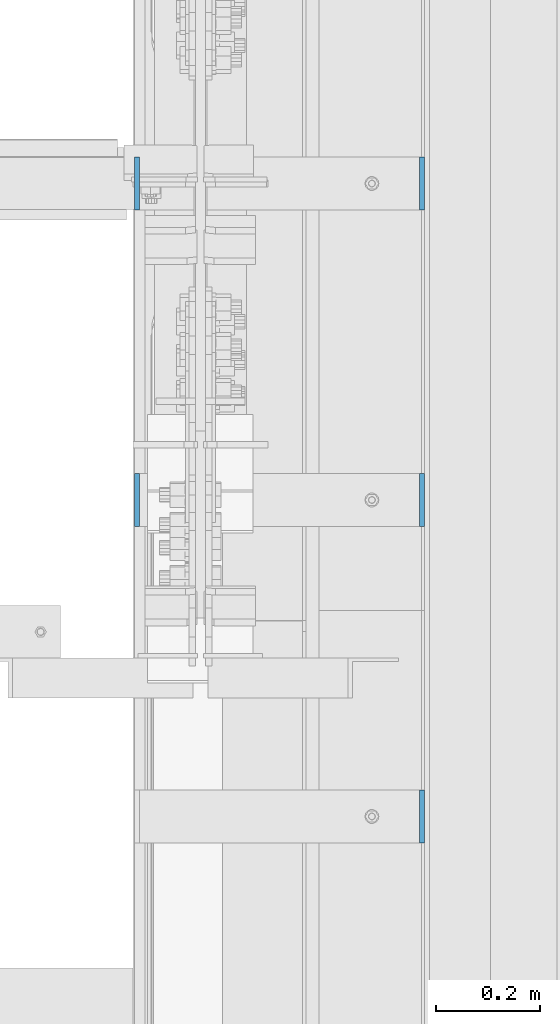
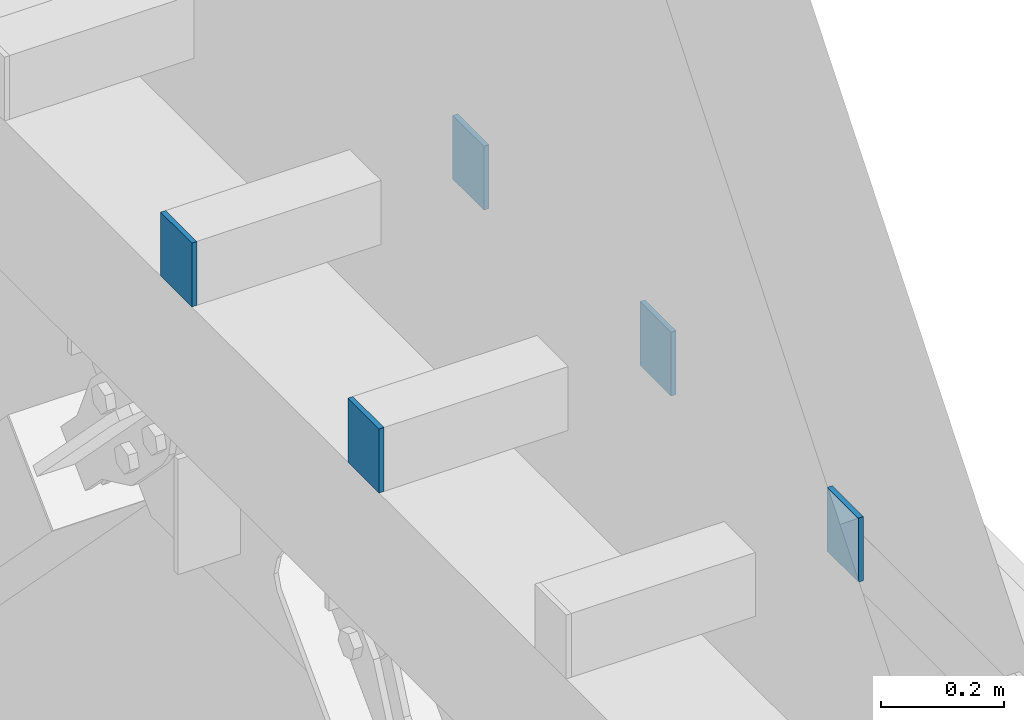
# One storey, part 414 of 1179: 5 columns, 3 elements without a shape of their own.
"""IFC2X3 building model written with IfcOpenShell, lengths in millimetres."""

from ifc_helpers import new_model, si_unit, frame, origin_with_axes, place, context, subcontext, project, spatial, faceted_brep, material, type_object, element, aggregate, save


model = new_model("IFC2X3")

# Units and contexts
model_context = context("Model", 3, precision=1e-05, world=origin_with_axes())
body_context = subcontext(model_context, "Body", "Model", "MODEL_VIEW")
ifc_project = project(units=[si_unit("LENGTHUNIT", "METRE", prefix="MILLI"), si_unit("AREAUNIT", "SQUARE_METRE"), si_unit("VOLUMEUNIT", "CUBIC_METRE"), si_unit("MASSUNIT", "GRAM", prefix="KILO"), si_unit("TIMEUNIT", "SECOND"), si_unit("PLANEANGLEUNIT", "RADIAN"), si_unit("SOLIDANGLEUNIT", "STERADIAN"), si_unit("THERMODYNAMICTEMPERATUREUNIT", "DEGREE_CELSIUS"), si_unit("LUMINOUSINTENSITYUNIT", "LUMEN")], contexts=[model_context])

# Site, building, storey
site_placement = place(None, origin_with_axes())
site = spatial("IfcSite", under=ifc_project, at=site_placement, CompositionType="ELEMENT")
building_placement = place(site_placement, origin_with_axes())
building = spatial("IfcBuilding", under=site, at=building_placement, Name="Undefined", CompositionType="ELEMENT")
storey_placement = place(building_placement, origin_with_axes())
storey = spatial("IfcBuildingStorey", under=building, at=storey_placement, Name="Undefined", CompositionType="ELEMENT", Elevation=0.0)

# Assembly, columns
assembly_1_placement = place(storey_placement, origin_with_axes())
assembly_1 = element("IfcElementAssembly", 1, at=assembly_1_placement, inside=storey, Name="BEAM", AssemblyPlace="NOTDEFINED", PredefinedType="RIGID_FRAME")
ifc_material = material(Name="STEEL/A36")
column_type = type_object("IfcColumnType", PredefinedType="NOTDEFINED")
column_1_placement = place(assembly_1_placement, frame((24734.8375, 15354.3, 8013.69999998781), z_axis=(0.0, 1.0, 0.0), x_axis=(0.0, 0.0, 1.0)))
column_1 = element("IfcColumn", 2, at=column_1_placement, type_object=column_type, material=ifc_material, Name="PLATE", context=body_context, shape_type="Brep", body=[
    faceted_brep([(0.0, 4.76249999999982, -50.7999999999993), (0.0, 4.76249999999982, 50.7999999999993), (127.000000000371, 4.76249999928405, 50.8000000000002), (127.000000000371, 4.76249999928405, -50.8000000000002), (0.0, -4.76249999999982, 50.7999999999993), (127.0, -4.76250000000073, 50.7999999999993), (0.0, -4.76249999999982, -50.7999999999993), (127.0, -4.76250000000073, -50.7999999999993)], [[[0, 1, 2, 3]], [[1, 4, 5, 2]], [[4, 6, 7, 5]], [[6, 0, 3, 7]], [[5, 7, 3, 2]], [[6, 4, 1, 0]]]),
])
column_2_placement = place(assembly_1_placement, frame((24185.5625, 15354.3, 8013.69999998781), z_axis=(0.0, -1.0, 0.0), x_axis=(0.0, 0.0, 1.0)))
column_2 = element("IfcColumn", 3, at=column_2_placement, type_object=column_type, material=ifc_material, Name="PLATE", context=body_context, shape_type="Brep", body=[
    faceted_brep([(0.0, 4.76249999999982, -50.7999999999993), (0.0, 4.76249999999982, 50.7999999999993), (127.000000000371, 4.76249999928405, 50.8000000000002), (127.000000000371, 4.76249999928405, -50.8000000000002), (0.0, -4.76249999999982, 50.7999999999993), (127.0, -4.76250000000073, 50.7999999999993), (0.0, -4.76249999999982, -50.7999999999993), (127.0, -4.76250000000073, -50.7999999999993)], [[[0, 1, 2, 3]], [[1, 4, 5, 2]], [[4, 6, 7, 5]], [[6, 0, 3, 7]], [[5, 7, 3, 2]], [[6, 4, 1, 0]]]),
])
aggregate(assembly_1, [column_1, column_2])

assembly_2_placement = place(storey_placement, origin_with_axes())
assembly_2 = element("IfcElementAssembly", 4, at=assembly_2_placement, inside=storey, Name="BEAM", AssemblyPlace="NOTDEFINED", PredefinedType="RIGID_FRAME")
column_3_placement = place(assembly_2_placement, frame((24734.8375, 14744.7, 8013.69999998781), z_axis=(0.0, 1.0, 0.0), x_axis=(0.0, 0.0, 1.0)))
column_3 = element("IfcColumn", 5, at=column_3_placement, type_object=column_type, material=ifc_material, Name="PLATE", context=body_context, shape_type="Brep", body=[
    faceted_brep([(0.0, 4.76249999999982, -50.7999999999993), (0.0, 4.76249999999982, 50.7999999999993), (127.000000000371, 4.76249999928405, 50.8000000000002), (127.000000000371, 4.76249999928405, -50.8000000000002), (0.0, -4.76249999999982, 50.7999999999993), (127.0, -4.76250000000073, 50.7999999999993), (0.0, -4.76249999999982, -50.7999999999993), (127.0, -4.76250000000073, -50.7999999999993)], [[[0, 1, 2, 3]], [[1, 4, 5, 2]], [[4, 6, 7, 5]], [[6, 0, 3, 7]], [[5, 7, 3, 2]], [[6, 4, 1, 0]]]),
])
column_4_placement = place(assembly_2_placement, frame((24185.5625, 14744.7, 8013.69999998781), z_axis=(0.0, -1.0, 0.0), x_axis=(0.0, 0.0, 1.0)))
column_4 = element("IfcColumn", 6, at=column_4_placement, type_object=column_type, material=ifc_material, Name="PLATE", context=body_context, shape_type="Brep", body=[
    faceted_brep([(0.0, 4.76249999999982, -50.7999999999993), (0.0, 4.76249999999982, 50.7999999999993), (127.000000000371, 4.76249999928405, 50.8000000000002), (127.000000000371, 4.76249999928405, -50.8000000000002), (0.0, -4.76249999999982, 50.7999999999993), (127.0, -4.76250000000073, 50.7999999999993), (0.0, -4.76249999999982, -50.7999999999993), (127.0, -4.76250000000073, -50.7999999999993)], [[[0, 1, 2, 3]], [[1, 4, 5, 2]], [[4, 6, 7, 5]], [[6, 0, 3, 7]], [[5, 7, 3, 2]], [[6, 4, 1, 0]]]),
])
aggregate(assembly_2, [column_3, column_4])

# Assembly, column
assembly_3_placement = place(storey_placement, origin_with_axes())
assembly_3 = element("IfcElementAssembly", 7, at=assembly_3_placement, inside=storey, Name="BEAM", AssemblyPlace="NOTDEFINED", PredefinedType="RIGID_FRAME")
column_5_placement = place(assembly_3_placement, frame((24734.8375, 14135.1, 8013.69999998781), z_axis=(0.0, 1.0, 0.0), x_axis=(0.0, 0.0, 1.0)))
column_5 = element("IfcColumn", 8, at=column_5_placement, type_object=column_type, material=ifc_material, Name="PLATE", context=body_context, shape_type="Brep", body=[
    faceted_brep([(0.0, 4.76249999999982, -50.7999999999993), (0.0, 4.76249999999982, 50.7999999999993), (127.000000000371, 4.76249999928405, 50.8000000000002), (127.000000000371, 4.76249999928405, -50.8000000000002), (0.0, -4.76249999999982, 50.7999999999993), (127.0, -4.76250000000073, 50.7999999999993), (0.0, -4.76249999999982, -50.7999999999993), (127.0, -4.76250000000073, -50.7999999999993)], [[[0, 1, 2, 3]], [[1, 4, 5, 2]], [[4, 6, 7, 5]], [[6, 0, 3, 7]], [[5, 7, 3, 2]], [[6, 4, 1, 0]]]),
])
aggregate(assembly_3, [column_5])

save(model, "model.ifc")
